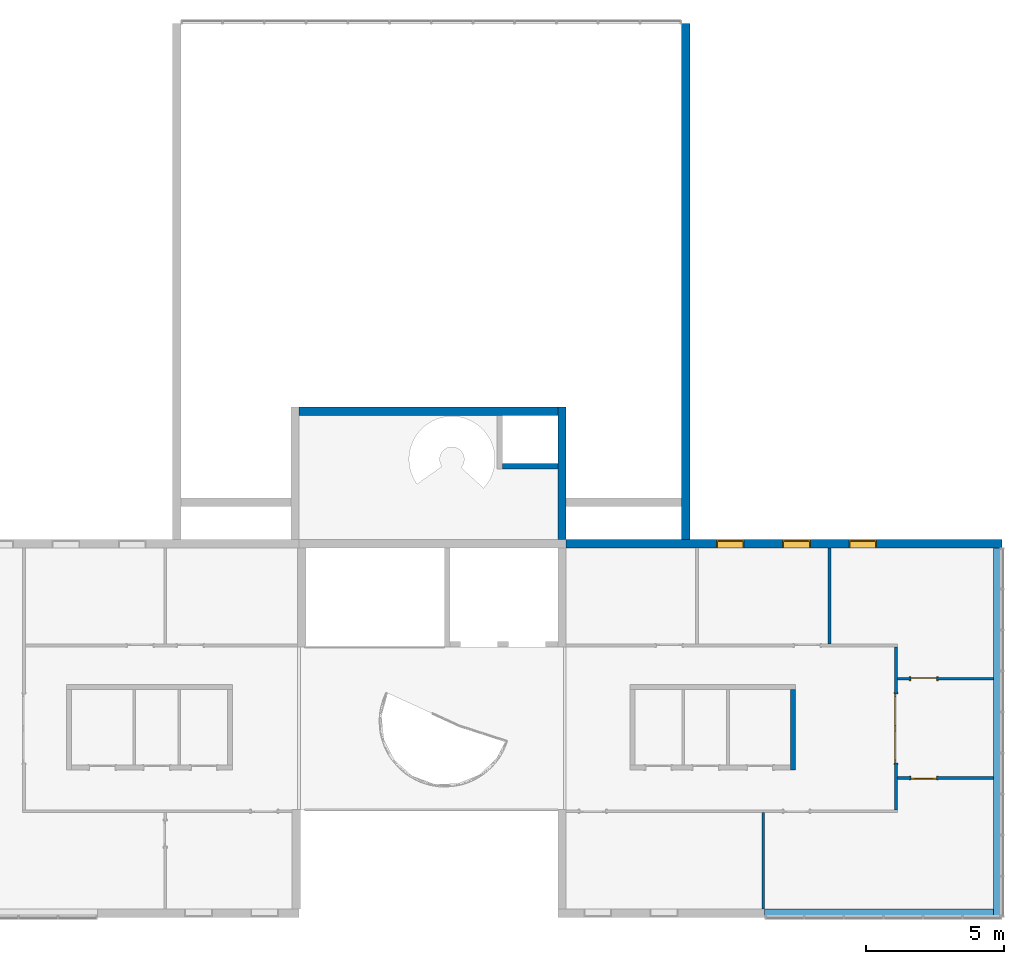
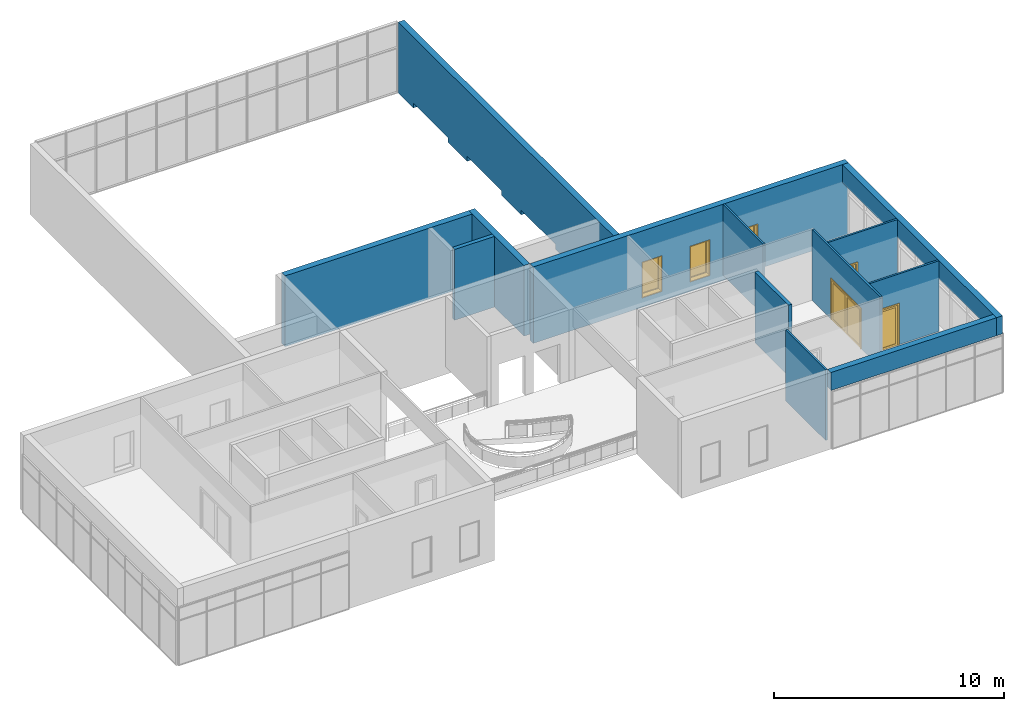
# One storey, part 12 of 13: 13 walls, 3 doors, 3 windows, 10 openings.
"""IFC2X3 building model written with IfcOpenShell, lengths in millimetres."""

from ifc_helpers import new_model, entity, si_unit, converted_unit, derived_unit, direction, frame, frame_2d, origin, origin_2d_with_axis, place, context, subcontext, project, spatial, polyline, rectangle, outline, extrude, clip, halfspace, source, transform, mapped, material, material_list, layer, layer_set, layer_usage, type_object, type_shapes, element, fill, save


model = new_model("IFC2X3")

# Units and contexts
model_context = context("Model", 3, precision=0.01, world=origin(), true_north=direction((6.12303176911189e-17, 1.0)))
context_of_model = context(None, 3, precision=0.01, world=origin(), true_north=direction((6.12303176911189e-17, 1.0)))
body_context = subcontext(model_context, "Body", "Model", "MODEL_VIEW")
ifc_project = project(units=[si_unit("LENGTHUNIT", "METRE", prefix="MILLI"), si_unit("AREAUNIT", "SQUARE_METRE"), si_unit("VOLUMEUNIT", "CUBIC_METRE"), converted_unit("PLANEANGLEUNIT", "DEGREE", entity("IfcRatioMeasure", 0.0174532925199433), si_unit("PLANEANGLEUNIT", "RADIAN"), dimensions=[0, 0, 0, 0, 0, 0, 0]), si_unit("MASSUNIT", "GRAM", prefix="KILO"), si_unit("TIMEUNIT", "SECOND"), si_unit("FREQUENCYUNIT", "HERTZ"), si_unit("THERMODYNAMICTEMPERATUREUNIT", "DEGREE_CELSIUS"), derived_unit("THERMALTRANSMITTANCEUNIT", [(si_unit("MASSUNIT", "GRAM", prefix="KILO"), 1), (si_unit("THERMODYNAMICTEMPERATUREUNIT", "KELVIN"), -1), (si_unit("TIMEUNIT", "SECOND"), -3)]), derived_unit("VOLUMETRICFLOWRATEUNIT", [(si_unit("LENGTHUNIT", "METRE"), 3), (si_unit("TIMEUNIT", "SECOND"), -1)]), si_unit("ELECTRICCURRENTUNIT", "AMPERE"), si_unit("ELECTRICVOLTAGEUNIT", "VOLT"), si_unit("POWERUNIT", "WATT"), si_unit("FORCEUNIT", "NEWTON", prefix="KILO"), si_unit("ILLUMINANCEUNIT", "LUX"), si_unit("LUMINOUSFLUXUNIT", "LUMEN"), si_unit("LUMINOUSINTENSITYUNIT", "CANDELA"), si_unit("PRESSUREUNIT", "PASCAL")], contexts=[model_context, context_of_model])

# Site, building, storey
site_placement = place(None, origin())
site = spatial("IfcSite", under=ifc_project, at=site_placement, CompositionType="ELEMENT")
building_placement = place(site_placement, origin())
building = spatial("IfcBuilding", under=site, at=building_placement, CompositionType="ELEMENT")
storey_placement = place(building_placement, frame((0.0, 0.0, 3750.0)))
storey = spatial("IfcBuildingStorey", under=building, at=storey_placement, Name="02. 2 etg.", CompositionType="ELEMENT", Elevation=3750.00000000068)

# Wall, openings
ifc_material_1 = material(Name="Brick, Engineering, Soldier Course")
ifc_layer_1 = layer(ifc_material_1, 300.0)
ifc_layer_set_1 = layer_set([ifc_layer_1], Name="Basic Wall:Generic - 300mm")
ifc_layer_usage_1 = layer_usage(ifc_layer_set_1, "AXIS2", "NEGATIVE", 150.0)
wall_type_1 = type_object("IfcWallType", Name="Basic Wall:Generic - 300mm", PredefinedType="STANDARD", material=ifc_layer_set_1)
wall_1_placement = place(storey_placement, frame((29649.1178561748, 18930.0, 0.0), z_axis=(0.0, 0.0, 1.0), x_axis=(0.0, -1.0, 0.0)))
wall_1 = element("IfcWallStandardCase", 1, at=wall_1_placement, inside=storey, type_object=wall_type_1, material=ifc_layer_usage_1, Name="Basic Wall:Generic - 300mm", ObjectType="Basic Wall:Generic - 300mm:6291", context=body_context, shape_type="Clipping", body=[
    clip(extrude(rectangle(XDim=18689.9999999999, YDim=300.000000000001, at=frame_2d((9344.99999999997, -2.8421709430404e-14), x_axis=(-1.0, 0.0))), origin(), (0.0, 0.0, 1.0), 3749.99999999925), halfspace(frame((0.0, 0.0, -3750.0)), True)),
])
placement_1 = place(building_placement, origin())
placement_2 = place(placement_1, frame((29649.1178561748, 18930.0, 0.0), z_axis=(0.0, 0.0, 1.0), x_axis=(0.0, -1.0, 0.0)))
opening_1_placement = place(placement_2, frame((4322.5, 150.0, 0.0)))
element("IfcOpeningElement", 2, at=opening_1_placement, cuts=wall_1, Name="M_Overhead-Rolling:_3000X4000:1", ObjectType="Opening", context=body_context, shape_type="SweptSolid", body=[
    extrude(rectangle(XDim=4000.0, YDim=3000.0, at=frame_2d((2000.0, 1500.0), x_axis=(1.0, 0.0))), frame((0.0, 0.0, 0.0), z_axis=(0.0, -1.0, 0.0), x_axis=(0.0, 0.0, 1.0)), (0.0, 0.0, 1.0), 300.0),
])
opening_2_placement = place(placement_2, frame((8995.0, 150.0, 0.0)))
element("IfcOpeningElement", 3, at=opening_2_placement, cuts=wall_1, Name="M_Overhead-Rolling:_3000X4000:1", ObjectType="Opening", context=body_context, shape_type="SweptSolid", body=[
    extrude(rectangle(XDim=4000.0, YDim=3000.0, at=frame_2d((2000.0, 1500.0), x_axis=(1.0, 0.0))), frame((0.0, 0.0, 0.0), z_axis=(0.0, -1.0, 0.0), x_axis=(0.0, 0.0, 1.0)), (0.0, 0.0, 1.0), 300.0),
])
opening_3_placement = place(placement_2, frame((13667.5, 150.0, 0.0)))
element("IfcOpeningElement", 4, at=opening_3_placement, cuts=wall_1, Name="M_Overhead-Rolling:_3000X4000:1", ObjectType="Opening", context=body_context, shape_type="SweptSolid", body=[
    extrude(rectangle(XDim=4000.0, YDim=3000.0, at=frame_2d((2000.0, 1500.0), x_axis=(1.0, 0.0))), frame((0.0, 0.0, 0.0), z_axis=(0.0, -1.0, 0.0), x_axis=(0.0, 0.0, 1.0)), (0.0, 0.0, 1.0), 300.0),
])

# Walls
ifc_layer_usage_2 = layer_usage(ifc_layer_set_1, "AXIS2", "NEGATIVE", 150.0)
wall_2_placement = place(storey_placement, frame((25163.8966271322, 5040.0, 0.0), z_axis=(0.0, 0.0, 1.0), x_axis=(0.0, -1.0, 0.0)))
element("IfcWallStandardCase", 5, at=wall_2_placement, inside=storey, type_object=wall_type_1, material=ifc_layer_usage_2, Name="Basic Wall:Generic - 300mm", ObjectType="Basic Wall:Generic - 300mm:6291", context=body_context, shape_type="Clipping", body=[
    clip(extrude(rectangle(XDim=4799.99999999996, YDim=300.000000000001, at=frame_2d((2399.99999999998, 8.38440428196918e-13), x_axis=(-1.0, 0.0))), origin(), (0.0, 0.0, 1.0), 3749.99999999993), halfspace(origin(), True)),
])
ifc_layer_usage_3 = layer_usage(ifc_layer_set_1, "AXIS2", "NEGATIVE", 150.0)
wall_3_placement = place(storey_placement, frame((15644.0, 4890.0, 0.0)))
element("IfcWallStandardCase", 6, at=wall_3_placement, inside=storey, type_object=wall_type_1, material=ifc_layer_usage_3, Name="Basic Wall:Generic - 300mm", ObjectType="Basic Wall:Generic - 300mm:6291", context=body_context, shape_type="Clipping", body=[
    clip(extrude(rectangle(XDim=9369.89662713216, YDim=300.0, at=frame_2d((4684.94831356608, -4.9737991503207e-13), x_axis=(-1.0, 0.0))), origin(), (0.0, 0.0, 1.0), 3749.99999999993), halfspace(origin(), True)),
])

# Wall, openings, windows
ifc_layer_usage_4 = layer_usage(ifc_layer_set_1, "AXIS2", "NEGATIVE", 150.0)
wall_4_placement = place(storey_placement, frame((25313.8966271322, 90.0, -300.0)))
wall_4 = element("IfcWallStandardCase", 7, at=wall_4_placement, inside=storey, type_object=wall_type_1, material=ifc_layer_usage_4, Name="Basic Wall:Generic - 300mm", ObjectType="Basic Wall:Generic - 300mm:6291", context=body_context, shape_type="SweptSolid", body=[
    extrude(rectangle(XDim=15784.3390852173, YDim=300.0, at=frame_2d((7892.16954260864, 0.0), x_axis=(-1.0, 0.0))), origin(), (0.0, 0.0, 1.0), 4049.99999999993),
])
opening_4_placement = place(wall_4_placement, frame((10244.3390852173, -150.0, 500.0)))
opening_4 = element("IfcOpeningElement", 8, at=opening_4_placement, cuts=wall_4, Name="M_Fixed:0406 x 0610mm:1", ObjectType="Opening", context=body_context, shape_type="SweptSolid", body=[
    extrude(rectangle(XDim=1900.0, YDim=1000.0, at=frame_2d((949.999999999998, 500.0), x_axis=(1.0, 0.0))), frame((0.0, 0.0, 0.0), z_axis=(0.0, 1.0, 0.0), x_axis=(0.0, 0.0, 1.0)), (0.0, 0.0, 1.0), 300.0),
])
opening_5_placement = place(wall_4_placement, frame((7844.33908521727, -150.0, 500.0)))
opening_5 = element("IfcOpeningElement", 9, at=opening_5_placement, cuts=wall_4, Name="M_Fixed:0406 x 0610mm:1", ObjectType="Opening", context=body_context, shape_type="SweptSolid", body=[
    extrude(rectangle(XDim=1900.0, YDim=1000.0, at=frame_2d((949.999999999998, 500.0), x_axis=(1.0, 0.0))), frame((0.0, 0.0, 0.0), z_axis=(0.0, 1.0, 0.0), x_axis=(0.0, 0.0, 1.0)), (0.0, 0.0, 1.0), 300.0),
])
opening_6_placement = place(wall_4_placement, frame((5444.33908521727, -150.0, 500.0)))
opening_6 = element("IfcOpeningElement", 10, at=opening_6_placement, cuts=wall_4, Name="M_Fixed:0406 x 0610mm:1", ObjectType="Opening", context=body_context, shape_type="SweptSolid", body=[
    extrude(rectangle(XDim=1900.0, YDim=1000.0, at=frame_2d((949.999999999998, 500.0), x_axis=(1.0, 0.0))), frame((0.0, 0.0, 0.0), z_axis=(0.0, 1.0, 0.0), x_axis=(0.0, 0.0, 1.0)), (0.0, 0.0, 1.0), 300.0),
])
ifc_material_2 = material(Name="Glass")
ifc_material_3 = material(Name="Stainless Steel")
ifc_material_list_1 = material_list([ifc_material_2, ifc_material_3])
ifc_material_list_2 = material_list([ifc_material_2, ifc_material_3])
window_style = type_object("IfcWindowStyle", Name="0406 x 0610mm", ConstructionType="NOTDEFINED", OperationType="NOTDEFINED", ParameterTakesPrecedence=False, Sizeable=False, material=ifc_material_list_2)
shared_shape_1 = source(origin(), body_context, "Body", "SweptSolid", [
    extrude(rectangle(XDim=873.999999999997, YDim=12.0, at=frame_2d((0.0, -8.43769498715119e-15), x_axis=(1.0, 0.0))), frame((500.0, 285.0, 63.0), z_axis=(0.0, 0.0, 1.0), x_axis=(-1.0, 0.0, 0.0)), (0.0, 0.0, 1.0), 1774.00000000001),
    extrude(outline(polyline([(-481.0, -931.0), (481.0, -931.0), (481.0, 931.0), (-481.0, 931.0), (-481.0, -931.0)]), holes=[polyline([(-437.0, -887.0), (-437.0, 887.0), (437.0, 887.0), (437.0, -887.0), (-437.0, -887.0)])]), frame((500.0, 307.0, 950.0), z_axis=(0.0, -1.0, 0.0), x_axis=(-1.0, 0.0, 0.0)), (0.0, 0.0, 1.0), 44.0000000000274),
    extrude(outline(polyline([(-500.0, -950.0), (500.0, -950.0), (500.0, 950.0), (-500.0, 950.0), (-500.0, -950.0)]), holes=[polyline([(-481.0, -931.0), (-481.0, 931.0), (481.0, 931.0), (481.0, -931.0), (-481.0, -931.0)])]), frame((500.0, 326.0, 950.0), z_axis=(0.0, -1.0, 0.0), x_axis=(-1.0, 0.0, 0.0)), (0.0, 0.0, 1.0), 63.0000000000274),
    extrude(outline(polyline([(-500.0, -950.0), (500.0, -950.0), (500.0, 950.0), (-500.0, 950.0), (-500.0, -950.0)]), holes=[polyline([(-468.0, -918.0), (-468.0, 918.0), (468.0, 918.0), (468.0, -918.0), (-468.0, -918.0)])]), frame((500.0, 263.0, 950.0), z_axis=(0.0, -1.0, 0.0), x_axis=(-1.0, 0.0, 0.0)), (0.0, 0.0, 1.0), 236.999999999973),
])
type_shapes(window_style, [shared_shape_1])
window_1_placement = place(opening_4_placement, frame((0.0, -26.0, 0.0)))
window_1 = element("IfcWindow", 11, at=window_1_placement, inside=storey, type_object=window_style, material=ifc_material_list_1, Name="M_Fixed:0406 x 0610mm", ObjectType="0406 x 0610mm", OverallHeight=1900.0, OverallWidth=999.999999999998, context=body_context, shape_type="MappedRepresentation", body=[
    mapped(shared_shape_1, transform((0.0, 0.0, 0.0), scale=1.0)),
])
fill(opening_4, window_1)
ifc_material_list_3 = material_list([ifc_material_2, ifc_material_3])
window_2_placement = place(opening_5_placement, frame((0.0, -26.0, 0.0)))
window_2 = element("IfcWindow", 12, at=window_2_placement, inside=storey, type_object=window_style, material=ifc_material_list_3, Name="M_Fixed:0406 x 0610mm", ObjectType="0406 x 0610mm", OverallHeight=1900.0, OverallWidth=999.999999999998, context=body_context, shape_type="MappedRepresentation", body=[
    mapped(shared_shape_1, transform((0.0, 0.0, 0.0), scale=1.0)),
])
fill(opening_5, window_2)
ifc_material_list_4 = material_list([ifc_material_2, ifc_material_3])
window_3_placement = place(opening_6_placement, frame((0.0, -26.0, 0.0)))
window_3 = element("IfcWindow", 13, at=window_3_placement, inside=storey, type_object=window_style, material=ifc_material_list_4, Name="M_Fixed:0406 x 0610mm", ObjectType="0406 x 0610mm", OverallHeight=1900.0, OverallWidth=999.999999999998, context=body_context, shape_type="MappedRepresentation", body=[
    mapped(shared_shape_1, transform((0.0, 0.0, 0.0), scale=1.0)),
])
fill(opening_6, window_3)

# Walls
ifc_layer_usage_5 = layer_usage(ifc_layer_set_1, "AXIS2", "POSITIVE", -150.0)
wall_5_placement = place(storey_placement, frame((40948.2357123495, -60.0, 2800.0), z_axis=(0.0, 0.0, 1.0), x_axis=(0.0, -1.0, 0.0)))
element("IfcWallStandardCase", 14, at=wall_5_placement, inside=storey, type_object=wall_type_1, material=ifc_layer_usage_5, Name="Basic Wall:Generic - 300mm", ObjectType="Basic Wall:Generic - 300mm:6291", context=body_context, shape_type="SweptSolid", body=[
    extrude(rectangle(XDim=13380.0000000001, YDim=300.000000000001, at=frame_2d((6690.00000000003, -1.09423581307055e-12), x_axis=(-1.0, 0.0))), origin(), (0.0, 0.0, 1.0), 949.999999999925),
])
ifc_layer_usage_6 = layer_usage(ifc_layer_set_1, "AXIS2", "NEGATIVE", 150.0)
wall_6_placement = place(storey_placement, frame((32508.2357123495, -13290.0, 2800.0)))
element("IfcWallStandardCase", 15, at=wall_6_placement, inside=storey, type_object=wall_type_1, material=ifc_layer_usage_6, Name="Basic Wall:Generic - 300mm", ObjectType="Basic Wall:Generic - 300mm:6291", context=body_context, shape_type="SweptSolid", body=[
    extrude(rectangle(XDim=8290.00000000003, YDim=300.000000000001, at=frame_2d((4145.00000000001, 4.68958205601666e-13), x_axis=(-1.0, 0.0))), origin(), (0.0, 0.0, 1.0), 949.999999999925),
])

# Wall, opening, door
ifc_material_4 = material(Name="Steel, Paint Finish, Ivory, Matte")
ifc_layer_2 = layer(ifc_material_4, 100.0)
ifc_layer_set_2 = layer_set([ifc_layer_2], Name="Basic Wall:_100mm")
ifc_layer_usage_7 = layer_usage(ifc_layer_set_2, "AXIS2", "POSITIVE", -50.0)
wall_type_2 = type_object("IfcWallType", Name="Basic Wall:_100mm", PredefinedType="STANDARD", material=ifc_layer_set_2)
wall_7_placement = place(storey_placement, frame((37258.2357123495, -9550.0, 0.0), z_axis=(0.0, 0.0, 1.0), x_axis=(0.0, 1.0, 0.0)))
wall_7 = element("IfcWallStandardCase", 16, at=wall_7_placement, inside=storey, type_object=wall_type_2, material=ifc_layer_usage_7, Name="Basic Wall:_100mm", ObjectType="Basic Wall:_100mm", context=body_context, shape_type="SweptSolid", body=[
    extrude(rectangle(XDim=5900.0, YDim=100.000000000003, at=frame_2d((2950.0, 0.0), x_axis=(-1.0, 0.0))), origin(), (0.0, 0.0, 1.0), 3750.0),
])
opening_7_placement = place(wall_7_placement, frame((1700.0, -50.0, 0.0)))
opening_7 = element("IfcOpeningElement", 17, at=opening_7_placement, cuts=wall_7, Name="M_Double-Glass 1:2500x2100:1", ObjectType="Opening", context=body_context, shape_type="SweptSolid", body=[
    extrude(rectangle(XDim=2500.0, YDim=2100.0, at=frame_2d((1050.0, 1250.0), x_axis=(0.0, 1.0))), frame((0.0, 0.0, 0.0), z_axis=(0.0, 1.0, 0.0), x_axis=(0.0, 0.0, 1.0)), (0.0, 0.0, 1.0), 100.0),
])
ifc_material_5 = material(Name="Metal - Stainless Steel,Polished")
ifc_material_6 = material(Name="Steel, Chrome Plated")
ifc_material_list_5 = material_list([ifc_material_5, ifc_material_2, ifc_material_6])
ifc_material_list_6 = material_list([ifc_material_5, ifc_material_2, ifc_material_6])
door_style_1 = type_object("IfcDoorStyle", Name="2500x2100", ConstructionType="NOTDEFINED", OperationType="DOUBLE_DOOR_SINGLE_SWING", ParameterTakesPrecedence=False, Sizeable=False, material=ifc_material_list_6)
shared_shape_2 = source(origin(), body_context, "Body", "SweptSolid", [
    extrude(outline(polyline([(-1326.0, -1069.0), (-1250.0, -1069.0), (-1250.0, 1031.0), (1250.0, 1031.0), (1250.0, -1069.0), (1326.0, -1069.0), (1326.0, 1107.0), (-1326.0, 1107.0), (-1326.0, -1069.0)])), frame((1250.0, -25.0, 1069.0), z_axis=(0.0, 1.0, 0.0), x_axis=(-1.0, 0.0, 0.0)), (0.0, 0.0, 1.0), 25.0),
    extrude(outline(polyline([(-1250.0, -1031.0), (-1250.0, 1069.0), (-1326.0, 1069.0), (-1326.0, -1107.0), (1326.0, -1107.0), (1326.0, 1069.0), (1250.0, 1069.0), (1250.0, -1031.0), (-1250.0, -1031.0)])), frame((1250.0, 100.0, 1069.0), z_axis=(0.0, -1.0, 0.0), x_axis=(-1.0, 0.0, 0.0)), (0.0, 0.0, -1.0), 24.999999999997),
    extrude(rectangle(XDim=7.14374999999973, YDim=1046.8, at=frame_2d((0.0, -5.6843418860808e-14), x_axis=(1.0, 0.0))), frame((1875.0, 78.1718749999958, 102.0), z_axis=(0.0, 0.0, 1.0), x_axis=(0.0, 1.0, 0.0)), (0.0, 0.0, 1.0), 1896.0),
    extrude(rectangle(XDim=7.14374999999973, YDim=1046.8, at=frame_2d((0.0, -5.6843418860808e-14), x_axis=(1.0, 0.0))), frame((625.0, 78.1718749999958, 102.0), z_axis=(0.0, 0.0, 1.0), x_axis=(0.0, 1.0, 0.0)), (0.0, 0.0, 1.0), 1896.0),
    extrude(outline(polyline([(-1050.0, -1250.0), (1050.0, -1250.0), (1050.0, 1250.0), (-1050.0, 1250.0), (-1050.0, -1250.0)]), holes=[polyline([(-948.0, 101.600000000038), (-948.0, 1148.40000000004), (948.0, 1148.40000000004), (948.0, 101.600000000038), (-948.0, 101.600000000038)]), polyline([(-948.0, -1148.39999999996), (-948.0, -101.599999999961), (948.0, -101.599999999961), (948.0, -1148.39999999996), (-948.0, -1148.39999999996)])]), frame((1250.0, 49.0, 1050.0), z_axis=(0.0, 1.0, 0.0), x_axis=(0.0, 0.0, -1.0)), (0.0, 0.0, 1.0), 51.0),
])
type_shapes(door_style_1, [shared_shape_2])
door_1_placement = place(opening_7_placement, origin())
door_1 = element("IfcDoor", 18, at=door_1_placement, inside=storey, type_object=door_style_1, material=ifc_material_list_5, Name="M_Double-Glass 1:2500x2100", ObjectType="2500x2100", OverallHeight=2100.0, OverallWidth=2500.0, context=body_context, shape_type="MappedRepresentation", body=[
    mapped(shared_shape_2, transform((0.0, 0.0, 0.0), scale=1.0)),
])
fill(opening_7, door_1)

# Wall
ifc_layer_usage_8 = layer_usage(ifc_layer_set_2, "AXIS2", "POSITIVE", -50.0)
wall_8_placement = place(storey_placement, frame((32458.2357123495, -13140.0, 0.0), z_axis=(0.0, 0.0, 1.0), x_axis=(0.0, 1.0, 0.0)))
element("IfcWallStandardCase", 19, at=wall_8_placement, inside=storey, type_object=wall_type_2, material=ifc_layer_usage_8, Name="Basic Wall:_100mm", ObjectType="Basic Wall:_100mm", context=body_context, shape_type="SweptSolid", body=[
    extrude(rectangle(XDim=3490.00000000005, YDim=100.000000000003, at=frame_2d((1745.00000000002, 0.0), x_axis=(-1.0, 0.0))), origin(), (0.0, 0.0, 1.0), 3750.0),
])

# Wall, opening, door
ifc_layer_usage_9 = layer_usage(ifc_layer_set_2, "AXIS2", "POSITIVE", -50.0)
wall_9_placement = place(storey_placement, frame((37308.2357123495, -4800.0, 0.0)))
wall_9 = element("IfcWallStandardCase", 20, at=wall_9_placement, inside=storey, type_object=wall_type_2, material=ifc_layer_usage_9, Name="Basic Wall:_100mm", ObjectType="Basic Wall:_100mm", context=body_context, shape_type="SweptSolid", body=[
    extrude(rectangle(XDim=3490.00000000001, YDim=100.0, at=frame_2d((1745.0, 0.0), x_axis=(-1.0, 0.0))), origin(), (0.0, 0.0, 1.0), 3750.0),
])
opening_8_placement = place(wall_9_placement, frame((500.0, -50.0, 0.0)))
opening_8 = element("IfcOpeningElement", 21, at=opening_8_placement, cuts=wall_9, Name="M_Single-Glass 1:0915 x 2134mm:1", ObjectType="Opening", context=body_context, shape_type="SweptSolid", body=[
    extrude(rectangle(XDim=914.999999999999, YDim=2134.0, at=frame_2d((1067.0, 457.5), x_axis=(0.0, -1.0))), frame((0.0, 0.0, 0.0), z_axis=(0.0, 1.0, 0.0), x_axis=(0.0, 0.0, 1.0)), (0.0, 0.0, 1.0), 100.0),
])
ifc_material_list_7 = material_list([ifc_material_3, ifc_material_2])
ifc_material_list_8 = material_list([ifc_material_3, ifc_material_2])
door_style_2 = type_object("IfcDoorStyle", Name="0915 x 2134mm", ConstructionType="NOTDEFINED", OperationType="SINGLE_SWING_LEFT", ParameterTakesPrecedence=False, Sizeable=False, material=ifc_material_list_8)
shared_shape_3 = source(origin(), body_context, "Body", "SweptSolid", [
    extrude(outline(polyline([(-457.500000000003, -1048.0), (-457.500000000003, 1086.0), (-533.499999999999, 1086.0), (-533.499999999999, -1124.0), (533.500000000001, -1124.0), (533.500000000001, 1086.0), (457.500000000001, 1086.0), (457.500000000001, -1048.0), (-457.500000000003, -1048.0)])), frame((457.499999999999, 0.0, 1086.0), z_axis=(0.0, 1.0, 0.0), x_axis=(1.0, 0.0, 0.0)), (0.0, 0.0, -1.0), 25.0),
    extrude(outline(polyline([(-457.500000000001, -1048.0), (-457.500000000001, 1086.0), (-533.499999999997, 1086.0), (-533.499999999997, -1124.0), (533.499999999999, -1124.0), (533.499999999999, 1086.0), (457.499999999999, 1086.0), (457.499999999999, -1048.0), (-457.500000000001, -1048.0)])), frame((457.500000000001, 125.0, 1086.0), z_axis=(0.0, 1.0, 0.0), x_axis=(1.0, 0.0, 0.0)), (0.0, 0.0, -1.0), 25.0000000000156),
    extrude(rectangle(XDim=711.0, YDim=6.35, at=origin_2d_with_axis()), frame((457.5, 74.6000000000257, 102.0)), (0.0, 0.0, 1.0), 1930.0),
    extrude(outline(polyline([(-1067.0, -457.499999999998), (1067.0, -457.499999999998), (1067.0, 457.499999999998), (-1067.0, 457.499999999998), (-1067.0, -457.499999999998)]), holes=[polyline([(-965.0, 355.499999999998), (965.0, 355.499999999998), (965.0, -355.500000000002), (-965.0, -355.500000000002), (-965.0, 355.499999999998)])]), frame((457.500000000002, 100.0, 1067.0), z_axis=(0.0, -1.0, 0.0), x_axis=(0.0, 0.0, -1.0)), (0.0, 0.0, 1.0), 51.0),
])
type_shapes(door_style_2, [shared_shape_3])
door_2_placement = place(opening_8_placement, origin())
door_2 = element("IfcDoor", 22, at=door_2_placement, inside=storey, type_object=door_style_2, material=ifc_material_list_7, Name="M_Single-Glass 1:0915 x 2134mm", ObjectType="0915 x 2134mm", OverallHeight=2134.0, OverallWidth=915.0, context=body_context, shape_type="MappedRepresentation", body=[
    mapped(shared_shape_3, transform((0.0, 0.0, 0.0), scale=1.0)),
])
fill(opening_8, door_2)

ifc_layer_usage_10 = layer_usage(ifc_layer_set_2, "AXIS2", "POSITIVE", -50.0)
wall_10_placement = place(storey_placement, frame((37308.2357123495, -8400.0, 0.0)))
wall_10 = element("IfcWallStandardCase", 23, at=wall_10_placement, inside=storey, type_object=wall_type_2, material=ifc_layer_usage_10, Name="Basic Wall:_100mm", ObjectType="Basic Wall:_100mm", context=body_context, shape_type="SweptSolid", body=[
    extrude(rectangle(XDim=3490.00000000002, YDim=99.9999999999989, at=frame_2d((1745.00000000001, 0.0), x_axis=(-1.0, 0.0))), origin(), (0.0, 0.0, 1.0), 3750.0),
])
opening_9_placement = place(wall_10_placement, frame((1415.0, 50.0, 0.0)))
opening_9 = element("IfcOpeningElement", 24, at=opening_9_placement, cuts=wall_10, Name="M_Single-Glass 1:0915 x 2134mm:1", ObjectType="Opening", context=body_context, shape_type="SweptSolid", body=[
    extrude(rectangle(XDim=914.999999999999, YDim=2134.0, at=frame_2d((1067.0, 457.5), x_axis=(0.0, 1.0))), frame((0.0, 0.0, 0.0), z_axis=(0.0, -1.0, 0.0), x_axis=(0.0, 0.0, 1.0)), (0.0, 0.0, 1.0), 100.0),
])
ifc_material_list_9 = material_list([ifc_material_3, ifc_material_2])
ifc_material_list_10 = material_list([ifc_material_3, ifc_material_2])
door_style_3 = type_object("IfcDoorStyle", Name="0915 x 2134mm", ConstructionType="NOTDEFINED", OperationType="SINGLE_SWING_RIGHT", ParameterTakesPrecedence=False, Sizeable=False, material=ifc_material_list_10)
shared_shape_4 = source(origin(), body_context, "Body", "SweptSolid", [
    extrude(outline(polyline([(-457.500000000003, -1048.0), (-457.500000000003, 1086.0), (-533.499999999999, 1086.0), (-533.499999999999, -1124.0), (533.500000000001, -1124.0), (533.500000000001, 1086.0), (457.500000000001, 1086.0), (457.500000000001, -1048.0), (-457.500000000003, -1048.0)])), frame((457.500000000001, -25.0, 1086.0), z_axis=(0.0, -1.0, 0.0), x_axis=(-1.0, 0.0, 0.0)), (0.0, 0.0, -1.0), 25.0),
    extrude(outline(polyline([(-457.500000000001, -1048.0), (-457.500000000001, 1086.0), (-533.499999999997, 1086.0), (-533.499999999997, -1124.0), (533.499999999999, -1124.0), (533.499999999999, 1086.0), (457.499999999999, 1086.0), (457.499999999999, -1048.0), (-457.500000000001, -1048.0)])), frame((457.499999999999, 100.0, 1086.0), z_axis=(0.0, -1.0, 0.0), x_axis=(-1.0, 0.0, 0.0)), (0.0, 0.0, -1.0), 25.0000000000156),
    extrude(rectangle(XDim=6.35, YDim=711.0, at=frame_2d((-4.21884749357559e-15, 0.0), x_axis=(1.0, 0.0))), frame((457.5, 74.6000000000039, 102.0), z_axis=(0.0, 0.0, 1.0), x_axis=(0.0, 1.0, 0.0)), (0.0, 0.0, 1.0), 1930.0),
    extrude(outline(polyline([(-1067.0, -457.499999999998), (1067.0, -457.499999999998), (1067.0, 457.499999999998), (-1067.0, 457.499999999998), (-1067.0, -457.499999999998)]), holes=[polyline([(-965.0, 355.499999999998), (965.0, 355.499999999998), (965.0, -355.500000000002), (-965.0, -355.500000000002), (-965.0, 355.499999999998)])]), frame((457.499999999998, 49.0, 1067.0), z_axis=(0.0, 1.0, 0.0), x_axis=(0.0, 0.0, -1.0)), (0.0, 0.0, 1.0), 51.0),
])
type_shapes(door_style_3, [shared_shape_4])
door_3_placement = place(opening_9_placement, frame((0.0, 0.0, 0.0), z_axis=(0.0, 0.0, 1.0), x_axis=(-1.0, 0.0, 0.0)))
door_3 = element("IfcDoor", 25, at=door_3_placement, inside=storey, type_object=door_style_3, material=ifc_material_list_9, Name="M_Single-Glass 1:0915 x 2134mm", ObjectType="0915 x 2134mm", OverallHeight=2134.0, OverallWidth=915.0, context=body_context, shape_type="MappedRepresentation", body=[
    mapped(shared_shape_4, transform((0.0, 0.0, 0.0), scale=1.0)),
])
fill(opening_9, door_3)

# Walls
ifc_layer_usage_11 = layer_usage(ifc_layer_set_2, "AXIS2", "POSITIVE", -50.0)
wall_11_placement = place(storey_placement, frame((34858.2357123495, -3550.0, 0.0), z_axis=(0.0, 0.0, 1.0), x_axis=(0.0, 1.0, 0.0)))
element("IfcWallStandardCase", 26, at=wall_11_placement, inside=storey, type_object=wall_type_2, material=ifc_layer_usage_11, Name="Basic Wall:_100mm", ObjectType="Basic Wall:_100mm", context=body_context, shape_type="SweptSolid", body=[
    extrude(rectangle(XDim=3490.00000000001, YDim=100.000000000003, at=frame_2d((1745.00000000001, 0.0), x_axis=(-1.0, 0.0))), origin(), (0.0, 0.0, 1.0), 3750.0),
])
ifc_layer_3 = layer(ifc_material_4, 180.0)
ifc_layer_set_3 = layer_set([ifc_layer_3], Name="Basic Wall:_180mm")
ifc_layer_usage_12 = layer_usage(ifc_layer_set_3, "AXIS2", "POSITIVE", -90.0)
wall_type_3 = type_object("IfcWallType", Name="Basic Wall:_180mm", PredefinedType="STANDARD", material=ifc_layer_set_3)
wall_12_placement = place(storey_placement, frame((33539.1178561747, -8106.65631369453, 0.0), z_axis=(0.0, 0.0, 1.0), x_axis=(0.0, 1.0, 0.0)))
element("IfcWallStandardCase", 27, at=wall_12_placement, inside=storey, type_object=wall_type_3, material=ifc_layer_usage_12, Name="Basic Wall:_180mm", ObjectType="Basic Wall:_180mm", context=body_context, shape_type="SweptSolid", body=[
    extrude(rectangle(XDim=2920.0, YDim=180.000000000002, at=frame_2d((1460.0, 0.0), x_axis=(-1.0, 0.0))), origin(), (0.0, 0.0, 1.0), 3750.0),
])

# Wall, opening
ifc_material_7 = material(Name="Default Wall")
ifc_layer_4 = layer(ifc_material_7, 200.0)
ifc_layer_set_4 = layer_set([ifc_layer_4], Name="Basic Wall:Generic - 200mm")
ifc_layer_usage_13 = layer_usage(ifc_layer_set_4, "AXIS2", "NEGATIVE", 100.0)
wall_type_4 = type_object("IfcWallType", Name="Basic Wall:Generic - 200mm", PredefinedType="STANDARD", material=ifc_layer_set_4)
wall_13_placement = place(storey_placement, frame((23013.8966271322, 2890.0, 0.0)))
wall_13 = element("IfcWallStandardCase", 28, at=wall_13_placement, inside=storey, type_object=wall_type_4, material=ifc_layer_usage_13, Name="Basic Wall:Generic - 200mm", ObjectType="Basic Wall:Generic - 200mm:398", context=body_context, shape_type="Clipping", body=[
    clip(extrude(rectangle(XDim=2000.00000000001, YDim=200.0, at=frame_2d((1000.0, -4.9737991503207e-14), x_axis=(-1.0, 0.0))), origin(), (0.0, 0.0, 1.0), 3749.99999999993), halfspace(origin(), True)),
])
opening_10_placement = place(wall_13_placement, frame((293.996439373994, -1624.0, 3750.0)))
element("IfcOpeningElement", 29, at=opening_10_placement, cuts=wall_13, Name="Basic Wall:Generic - 200mm", ObjectType="Opening", context=body_context, shape_type="SweptSolid", body=[
    extrude(rectangle(XDim=2100.0, YDim=1340.00356586779, at=frame_2d((0.0, -4.32009983342141e-12), x_axis=(1.0, 0.0))), frame((670.001782933896, 0.0, 1050.0), z_axis=(0.0, 1.0, 0.0), x_axis=(0.0, 0.0, -1.0)), (0.0, 0.0, 1.0), 3048.0),
])

save(model, "model.ifc")
